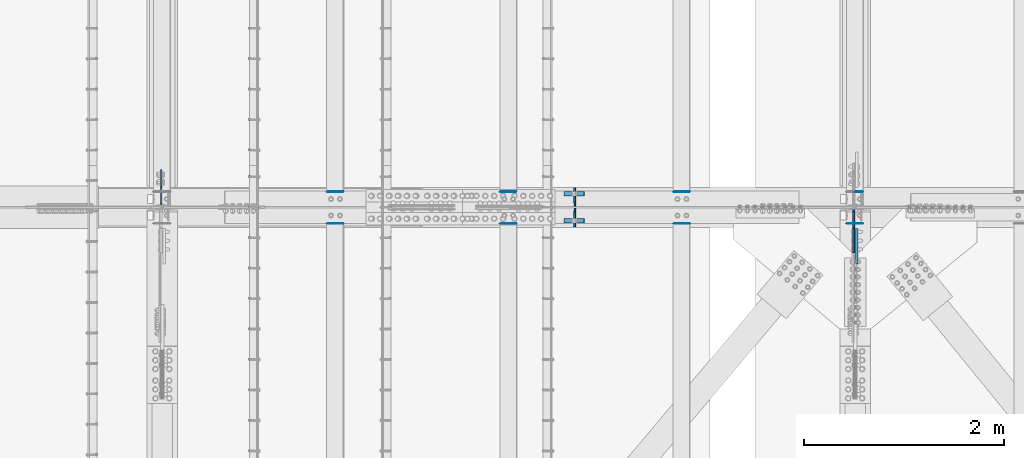
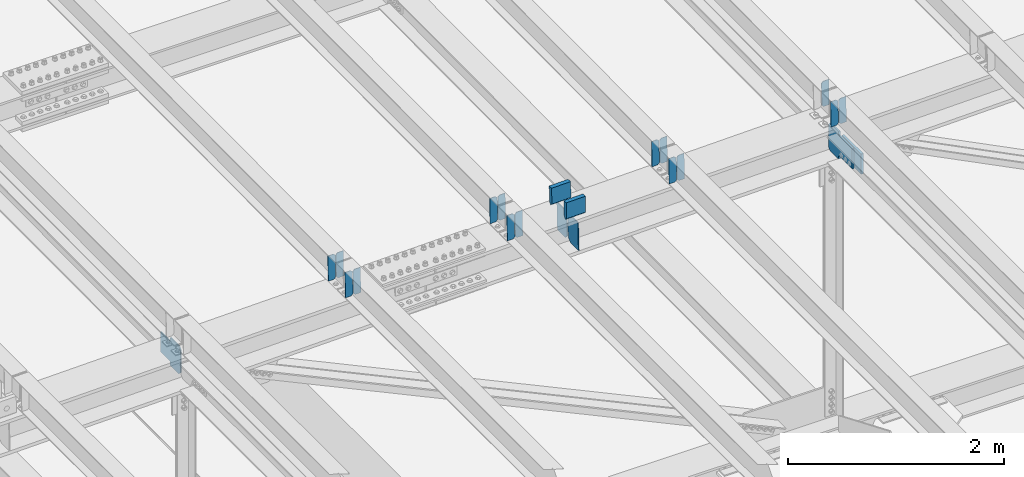
# One storey, part 3290 of 3843: 22 plates, 11 elements without a shape of their own.
"""IFC2X3 building model written with IfcOpenShell, lengths in millimetres."""

from ifc_helpers import new_model, si_unit, frame, origin_with_axes, place, context, subcontext, project, spatial, faceted_brep, material, type_object, element, aggregate, save


model = new_model("IFC2X3")

# Units and contexts
model_context = context("Model", 3, precision=1e-05, world=origin_with_axes())
body_context = subcontext(model_context, "Body", "Model", "MODEL_VIEW")
ifc_project = project(units=[si_unit("LENGTHUNIT", "METRE", prefix="MILLI"), si_unit("AREAUNIT", "SQUARE_METRE"), si_unit("VOLUMEUNIT", "CUBIC_METRE"), si_unit("MASSUNIT", "GRAM", prefix="KILO"), si_unit("TIMEUNIT", "SECOND"), si_unit("PLANEANGLEUNIT", "RADIAN"), si_unit("SOLIDANGLEUNIT", "STERADIAN"), si_unit("THERMODYNAMICTEMPERATUREUNIT", "DEGREE_CELSIUS"), si_unit("LUMINOUSINTENSITYUNIT", "LUMEN")], contexts=[model_context])

# Site, building, storey
site_placement = place(None, origin_with_axes())
site = spatial("IfcSite", under=ifc_project, at=site_placement, CompositionType="ELEMENT")
building_placement = place(site_placement, origin_with_axes())
building = spatial("IfcBuilding", under=site, at=building_placement, Name="Undefined", CompositionType="ELEMENT")
storey_placement = place(building_placement, origin_with_axes())
storey = spatial("IfcBuildingStorey", under=building, at=storey_placement, Name="Undefined", CompositionType="ELEMENT", Elevation=0.0)

# Assembly, plate
assembly_1_placement = place(storey_placement, origin_with_axes())
assembly_1 = element("IfcElementAssembly", 1, at=assembly_1_placement, inside=storey, Name="BEAM", AssemblyPlace="NOTDEFINED", PredefinedType="RIGID_FRAME")
ifc_material = material(Name="STEEL/A572-50")
plate_type_1 = type_object("IfcPlateType", PredefinedType="NOTDEFINED")
plate_1_placement = place(assembly_1_placement, frame((56013.0964783436, 34003.2151362822, 45851.1922234992), z_axis=(-0.0211520978450862, -0.00720209800074371, 0.999750328102542), x_axis=(-0.999776269350674, 0.000152374000020299, -0.0211515490073949)))
plate_1 = element("IfcPlate", 2, at=plate_1_placement, type_object=plate_type_1, material=ifc_material, Name="PLATE", context=body_context, shape_type="Brep", body=[
    faceted_brep([(0.0, -3.17499999999927, 0.0), (6.83940015733242e-10, -3.17499999996653, 288.924999998613), (6.54836185276508e-10, 3.17500000001746, 288.924999998591), (0.0, 3.17499999999927, 0.0), (60.3250007643655, -3.17500000017753, 288.924999998606), (60.3250007643219, 3.17499999979918, 288.924999998584), (79.3750000013097, -3.17500000025029, 269.875000761494), (79.375000001266, 3.17499999972642, 269.875000761487), (79.375000000713, -3.17500000026484, 19.0499992370605), (79.3750000006985, 3.17499999971187, 19.0499992370533), (60.325000763667, -3.17500000020664, -1.45519152283669e-11), (60.3250007636234, 3.17499999977736, -3.63797880709171e-11)], [[[0, 1, 2, 3]], [[1, 4, 5, 2]], [[4, 6, 7, 5]], [[6, 8, 9, 7]], [[8, 10, 11, 9]], [[10, 0, 3, 11]], [[5, 7, 9, 11, 3, 2]], [[10, 8, 6, 4, 1, 0]]]),
])
aggregate(assembly_1, [plate_1])

# Assembly, plates
assembly_2_placement = place(storey_placement, origin_with_axes())
assembly_2 = element("IfcElementAssembly", 3, at=assembly_2_placement, inside=storey, Name="BEAM", AssemblyPlace="NOTDEFINED", PredefinedType="RIGID_FRAME")
plate_2_placement = place(assembly_2_placement, frame((56013.0964782657, 33683.8902484388, 45849.8849977929), z_axis=(-0.0211520978121262, -0.00105623500043294, 0.999775711410199), x_axis=(-0.999776269351372, 2.23470000204419e-05, -0.0211520860074212)))
plate_2 = element("IfcPlate", 4, at=plate_2_placement, type_object=plate_type_1, material=ifc_material, Name="PLATE", context=body_context, shape_type="Brep", body=[
    faceted_brep([(0.0, -3.17499999999927, 0.0), (6.83940015733242e-10, -3.17499999996653, 288.924999998613), (6.54836185276508e-10, 3.17500000001746, 288.924999998591), (0.0, 3.17499999999927, 0.0), (60.3250007643655, -3.17500000017753, 288.924999998606), (60.3250007643219, 3.17499999979918, 288.924999998584), (79.3750000013097, -3.17500000025029, 269.875000761494), (79.375000001266, 3.17499999972642, 269.875000761487), (79.375000000713, -3.17500000026484, 19.0499992370605), (79.3750000006985, 3.17499999971187, 19.0499992370533), (60.325000763667, -3.17500000020664, -1.45519152283669e-11), (60.3250007636234, 3.17499999977736, -3.63797880709171e-11)], [[[0, 1, 2, 3]], [[1, 4, 5, 2]], [[4, 6, 7, 5]], [[6, 8, 9, 7]], [[8, 10, 11, 9]], [[10, 0, 3, 11]], [[5, 7, 9, 11, 3, 2]], [[10, 8, 6, 4, 1, 0]]]),
])
plate_3_placement = place(assembly_2_placement, frame((55927.390657576, 33683.892164099, 45848.0717352026), z_axis=(-0.0211520978121262, -0.00105623500043294, 0.999775711410199), x_axis=(-0.999776269351372, 2.23470000204419e-05, -0.0211520860074212)))
plate_3 = element("IfcPlate", 5, at=plate_3_placement, type_object=plate_type_1, material=ifc_material, Name="PLATE", context=body_context, shape_type="Brep", body=[
    faceted_brep([(4.36557456851006e-11, -3.17499999998836, 19.0499992370969), (6.11180439591408e-10, -3.17499999996653, 269.875000761516), (5.96628524363041e-10, 3.17500000001746, 269.875000761502), (1.45519152283669e-11, 3.17499999998836, 19.0499992370824), (19.0499992376572, -3.17500000003201, 288.924999998606), (19.0499992376281, 3.1749999999447, 288.924999998584), (79.3750000013242, -3.17500000025029, 288.924999998591), (79.3750000013097, 3.1749999997337, 288.92499999857), (79.3750000006548, -3.17500000026484, -2.18278728425503e-11), (79.3750000006403, 3.17499999969732, -2.91038304567337e-11), (19.0499992370023, -3.17500000005384, 0.0), (19.0499992369587, 3.17499999992287, -1.45519152283669e-11)], [[[0, 1, 2, 3]], [[1, 4, 5, 2]], [[4, 6, 7, 5]], [[6, 8, 9, 7]], [[8, 10, 11, 9]], [[10, 0, 3, 11]], [[5, 7, 9, 11, 3, 2]], [[10, 8, 6, 4, 1, 0]]]),
])
aggregate(assembly_2, [plate_2, plate_3])

assembly_3_placement = place(storey_placement, origin_with_axes())
assembly_3 = element("IfcElementAssembly", 6, at=assembly_3_placement, inside=storey, Name="BEAM", AssemblyPlace="NOTDEFINED", PredefinedType="RIGID_FRAME")
plate_4_placement = place(assembly_3_placement, frame((54279.5464782748, 34003.1156939734, 45813.6257052676), z_axis=(-0.0211520978615081, -0.00686633299678943, 0.999752690532631), x_axis=(-0.999776269350327, 0.000145270000029235, -0.0211515990074044)))
plate_4 = element("IfcPlate", 7, at=plate_4_placement, type_object=plate_type_1, material=ifc_material, Name="PLATE", context=body_context, shape_type="Brep", body=[
    faceted_brep([(0.0, -3.17499999999927, 0.0), (6.83940015733242e-10, -3.17499999996653, 288.924999998613), (6.54836185276508e-10, 3.17500000001746, 288.924999998591), (0.0, 3.17499999999927, 0.0), (60.3250007643655, -3.17500000017753, 288.924999998606), (60.3250007643219, 3.17499999979918, 288.924999998584), (79.3750000013097, -3.17500000025029, 269.875000761494), (79.375000001266, 3.17499999972642, 269.875000761487), (79.375000000713, -3.17500000026484, 19.0499992370605), (79.3750000006985, 3.17499999971187, 19.0499992370533), (60.325000763667, -3.17500000020664, -1.45519152283669e-11), (60.3250007636234, 3.17499999977736, -3.63797880709171e-11)], [[[0, 1, 2, 3]], [[1, 4, 5, 2]], [[4, 6, 7, 5]], [[6, 8, 9, 7]], [[8, 10, 11, 9]], [[10, 0, 3, 11]], [[5, 7, 9, 11, 3, 2]], [[10, 8, 6, 4, 1, 0]]]),
])
plate_5_placement = place(assembly_3_placement, frame((54193.8406575855, 34003.1281472298, 45811.8124844316), z_axis=(-0.0211520978615081, -0.00686633299678943, 0.999752690532631), x_axis=(-0.999776269350327, 0.000145270000029235, -0.0211515990074044)))
plate_5 = element("IfcPlate", 8, at=plate_5_placement, type_object=plate_type_1, material=ifc_material, Name="PLATE", context=body_context, shape_type="Brep", body=[
    faceted_brep([(4.36557456851006e-11, -3.17499999998836, 19.0499992370969), (6.11180439591408e-10, -3.17499999996653, 269.875000761516), (5.96628524363041e-10, 3.17500000001746, 269.875000761502), (1.45519152283669e-11, 3.17499999998836, 19.0499992370824), (19.0499992376572, -3.17500000003201, 288.924999998606), (19.0499992376281, 3.1749999999447, 288.924999998584), (79.3750000013242, -3.17500000025029, 288.924999998591), (79.3750000013097, 3.1749999997337, 288.92499999857), (79.3750000006548, -3.17500000026484, -2.18278728425503e-11), (79.3750000006403, 3.17499999969732, -2.91038304567337e-11), (19.0499992370023, -3.17500000005384, 0.0), (19.0499992369587, 3.17499999992287, -1.45519152283669e-11)], [[[0, 1, 2, 3]], [[1, 4, 5, 2]], [[4, 6, 7, 5]], [[6, 8, 9, 7]], [[8, 10, 11, 9]], [[10, 0, 3, 11]], [[5, 7, 9, 11, 3, 2]], [[10, 8, 6, 4, 1, 0]]]),
])
aggregate(assembly_3, [plate_4, plate_5])

assembly_4_placement = place(storey_placement, origin_with_axes())
assembly_4 = element("IfcElementAssembly", 9, at=assembly_4_placement, inside=storey, Name="BEAM", AssemblyPlace="NOTDEFINED", PredefinedType="RIGID_FRAME")
plate_6_placement = place(assembly_4_placement, frame((54279.5464782638, 33683.8619929527, 45812.3874260212), z_axis=(-0.0211520977917825, -0.000961630999885527, 0.999775806881136), x_axis=(-0.999776269351802, 2.0345000001943e-05, -0.0211520880074333)))
plate_6 = element("IfcPlate", 10, at=plate_6_placement, type_object=plate_type_1, material=ifc_material, Name="PLATE", context=body_context, shape_type="Brep", body=[
    faceted_brep([(0.0, -3.17499999999927, 0.0), (6.83940015733242e-10, -3.17499999996653, 288.924999998613), (6.54836185276508e-10, 3.17500000001746, 288.924999998591), (0.0, 3.17499999999927, 0.0), (60.3250007643655, -3.17500000017753, 288.924999998606), (60.3250007643219, 3.17499999979918, 288.924999998584), (79.3750000013097, -3.17500000025029, 269.875000761494), (79.375000001266, 3.17499999972642, 269.875000761487), (79.375000000713, -3.17500000026484, 19.0499992370605), (79.3750000006985, 3.17499999971187, 19.0499992370533), (60.325000763667, -3.17500000020664, -1.45519152283669e-11), (60.3250007636234, 3.17499999977736, -3.63797880709171e-11)], [[[0, 1, 2, 3]], [[1, 4, 5, 2]], [[4, 6, 7, 5]], [[6, 8, 9, 7]], [[8, 10, 11, 9]], [[10, 0, 3, 11]], [[5, 7, 9, 11, 3, 2]], [[10, 8, 6, 4, 1, 0]]]),
])
plate_7_placement = place(assembly_4_placement, frame((54193.8406575745, 33683.8637370322, 45810.5741632592), z_axis=(-0.0211520977917825, -0.000961630999885527, 0.999775806881136), x_axis=(-0.999776269351802, 2.0345000001943e-05, -0.0211520880074333)))
plate_7 = element("IfcPlate", 11, at=plate_7_placement, type_object=plate_type_1, material=ifc_material, Name="PLATE", context=body_context, shape_type="Brep", body=[
    faceted_brep([(4.36557456851006e-11, -3.17499999998836, 19.0499992370969), (6.11180439591408e-10, -3.17499999996653, 269.875000761516), (5.96628524363041e-10, 3.17500000001746, 269.875000761502), (1.45519152283669e-11, 3.17499999998836, 19.0499992370824), (19.0499992376572, -3.17500000003201, 288.924999998606), (19.0499992376281, 3.1749999999447, 288.924999998584), (79.3750000013242, -3.17500000025029, 288.924999998591), (79.3750000013097, 3.1749999997337, 288.92499999857), (79.3750000006548, -3.17500000026484, -2.18278728425503e-11), (79.3750000006403, 3.17499999969732, -2.91038304567337e-11), (19.0499992370023, -3.17500000005384, 0.0), (19.0499992369587, 3.17499999992287, -1.45519152283669e-11)], [[[0, 1, 2, 3]], [[1, 4, 5, 2]], [[4, 6, 7, 5]], [[6, 8, 9, 7]], [[8, 10, 11, 9]], [[10, 0, 3, 11]], [[5, 7, 9, 11, 3, 2]], [[10, 8, 6, 4, 1, 0]]]),
])
aggregate(assembly_4, [plate_6, plate_7])

assembly_5_placement = place(storey_placement, origin_with_axes())
assembly_5 = element("IfcElementAssembly", 12, at=assembly_5_placement, inside=storey, Name="BEAM", AssemblyPlace="NOTDEFINED", PredefinedType="RIGID_FRAME")
plate_8_placement = place(assembly_5_placement, frame((52545.9964782752, 34002.9975009205, 45776.0491563071), z_axis=(-0.0211520975599923, -0.00646726799793394, 0.999755351680328), x_axis=(-0.999776269356706, 0.000136827000078921, -0.0211516550075725)))
plate_8 = element("IfcPlate", 13, at=plate_8_placement, type_object=plate_type_1, material=ifc_material, Name="PLATE", context=body_context, shape_type="Brep", body=[
    faceted_brep([(0.0, -3.17499999999927, 0.0), (6.83940015733242e-10, -3.17499999996653, 288.924999998613), (6.54836185276508e-10, 3.17500000001746, 288.924999998591), (0.0, 3.17499999999927, 0.0), (60.3250007643655, -3.17500000017753, 288.924999998606), (60.3250007643219, 3.17499999979918, 288.924999998584), (79.3750000013097, -3.17500000025029, 269.875000761494), (79.375000001266, 3.17499999972642, 269.875000761487), (79.375000000713, -3.17500000026484, 19.0499992370605), (79.3750000006985, 3.17499999971187, 19.0499992370533), (60.325000763667, -3.17500000020664, -1.45519152283669e-11), (60.3250007636234, 3.17499999977736, -3.63797880709171e-11)], [[[0, 1, 2, 3]], [[1, 4, 5, 2]], [[4, 6, 7, 5]], [[6, 8, 9, 7]], [[8, 10, 11, 9]], [[10, 0, 3, 11]], [[5, 7, 9, 11, 3, 2]], [[10, 8, 6, 4, 1, 0]]]),
])
plate_9_placement = place(assembly_5_placement, frame((52460.2906575859, 34003.0092304079, 45774.2359306445), z_axis=(-0.0211520975599923, -0.00646726799793394, 0.999755351680328), x_axis=(-0.999776269356706, 0.000136827000078921, -0.0211516550075725)))
plate_9 = element("IfcPlate", 14, at=plate_9_placement, type_object=plate_type_1, material=ifc_material, Name="PLATE", context=body_context, shape_type="Brep", body=[
    faceted_brep([(4.36557456851006e-11, -3.17499999998836, 19.0499992370969), (6.11180439591408e-10, -3.17499999996653, 269.875000761516), (5.96628524363041e-10, 3.17500000001746, 269.875000761502), (1.45519152283669e-11, 3.17499999998836, 19.0499992370824), (19.0499992376572, -3.17500000003201, 288.924999998606), (19.0499992376281, 3.1749999999447, 288.924999998584), (79.3750000013242, -3.17500000025029, 288.924999998591), (79.3750000013097, 3.1749999997337, 288.92499999857), (79.3750000006548, -3.17500000026484, -2.18278728425503e-11), (79.3750000006403, 3.17499999969732, -2.91038304567337e-11), (19.0499992370023, -3.17500000005384, 0.0), (19.0499992369587, 3.17499999992287, -1.45519152283669e-11)], [[[0, 1, 2, 3]], [[1, 4, 5, 2]], [[4, 6, 7, 5]], [[6, 8, 9, 7]], [[8, 10, 11, 9]], [[10, 0, 3, 11]], [[5, 7, 9, 11, 3, 2]], [[10, 8, 6, 4, 1, 0]]]),
])
aggregate(assembly_5, [plate_8, plate_9])

assembly_6_placement = place(storey_placement, origin_with_axes())
assembly_6 = element("IfcElementAssembly", 15, at=assembly_6_placement, inside=storey, Name="BEAM", AssemblyPlace="NOTDEFINED", PredefinedType="RIGID_FRAME")
plate_10_placement = place(assembly_6_placement, frame((52545.996478265, 33683.8312435383, 45774.8898608673), z_axis=(-0.0211520979617634, -0.000867027000342203, 0.999775893396113), x_axis=(-0.999776269348206, 1.83440000095906e-05, -0.0211520900074109)))
plate_10 = element("IfcPlate", 16, at=plate_10_placement, type_object=plate_type_1, material=ifc_material, Name="PLATE", context=body_context, shape_type="Brep", body=[
    faceted_brep([(0.0, -3.17499999999927, 0.0), (6.83940015733242e-10, -3.17499999996653, 288.924999998613), (6.54836185276508e-10, 3.17500000001746, 288.924999998591), (0.0, 3.17499999999927, 0.0), (60.3250007643655, -3.17500000017753, 288.924999998606), (60.3250007643219, 3.17499999979918, 288.924999998584), (79.3750000013097, -3.17500000025029, 269.875000761494), (79.375000001266, 3.17499999972642, 269.875000761487), (79.375000000713, -3.17500000026484, 19.0499992370605), (79.3750000006985, 3.17499999971187, 19.0499992370533), (60.325000763667, -3.17500000020664, -1.45519152283669e-11), (60.3250007636234, 3.17499999977736, -3.63797880709171e-11)], [[[0, 1, 2, 3]], [[1, 4, 5, 2]], [[4, 6, 7, 5]], [[6, 8, 9, 7]], [[8, 10, 11, 9]], [[10, 0, 3, 11]], [[5, 7, 9, 11, 3, 2]], [[10, 8, 6, 4, 1, 0]]]),
])
plate_11_placement = place(assembly_6_placement, frame((52460.2906575756, 33683.8328160392, 45773.0765979471), z_axis=(-0.0211520979617634, -0.000867027000342203, 0.999775893396113), x_axis=(-0.999776269348206, 1.83440000095906e-05, -0.0211520900074109)))
plate_11 = element("IfcPlate", 17, at=plate_11_placement, type_object=plate_type_1, material=ifc_material, Name="PLATE", context=body_context, shape_type="Brep", body=[
    faceted_brep([(4.36557456851006e-11, -3.17499999998836, 19.0499992370969), (6.11180439591408e-10, -3.17499999996653, 269.875000761516), (5.96628524363041e-10, 3.17500000001746, 269.875000761502), (1.45519152283669e-11, 3.17499999998836, 19.0499992370824), (19.0499992376572, -3.17500000003201, 288.924999998606), (19.0499992376281, 3.1749999999447, 288.924999998584), (79.3750000013242, -3.17500000025029, 288.924999998591), (79.3750000013097, 3.1749999997337, 288.92499999857), (79.3750000006548, -3.17500000026484, -2.18278728425503e-11), (79.3750000006403, 3.17499999969732, -2.91038304567337e-11), (19.0499992370023, -3.17500000005384, 0.0), (19.0499992369587, 3.17499999992287, -1.45519152283669e-11)], [[[0, 1, 2, 3]], [[1, 4, 5, 2]], [[4, 6, 7, 5]], [[6, 8, 9, 7]], [[8, 10, 11, 9]], [[10, 0, 3, 11]], [[5, 7, 9, 11, 3, 2]], [[10, 8, 6, 4, 1, 0]]]),
])
aggregate(assembly_6, [plate_10, plate_11])

assembly_7_placement = place(storey_placement, origin_with_axes())
assembly_7 = element("IfcElementAssembly", 18, at=assembly_7_placement, inside=storey, Name="BEAM", AssemblyPlace="NOTDEFINED", PredefinedType="RIGID_FRAME")
plate_12_placement = place(assembly_7_placement, frame((50812.4464782769, 34003.1037015849, 45731.7644254659), z_axis=(-0.0211520979861161, -0.00682580700029211, 0.999752968042396), x_axis=(-0.999776269353726, 0.000143930000091341, -0.021151608007443)))
plate_12 = element("IfcPlate", 19, at=plate_12_placement, type_object=plate_type_1, material=ifc_material, Name="PLATE", context=body_context, shape_type="Brep", body=[
    faceted_brep([(0.0, -3.17499999999927, 0.0), (6.83940015733242e-10, -3.17499999996653, 288.924999998613), (6.54836185276508e-10, 3.17500000001746, 288.924999998591), (0.0, 3.17499999999927, 0.0), (60.3250007643655, -3.17500000017753, 288.924999998606), (60.3250007643219, 3.17499999979918, 288.924999998584), (79.3750000013097, -3.17500000025029, 269.875000761494), (79.375000001266, 3.17499999972642, 269.875000761487), (79.375000000713, -3.17500000026484, 19.0499992370605), (79.3750000006985, 3.17499999971187, 19.0499992370533), (60.325000763667, -3.17500000020664, -1.45519152283669e-11), (60.3250007636234, 3.17499999977736, -3.63797880709171e-11)], [[[0, 1, 2, 3]], [[1, 4, 5, 2]], [[4, 6, 7, 5]], [[6, 8, 9, 7]], [[8, 10, 11, 9]], [[10, 0, 3, 11]], [[5, 7, 9, 11, 3, 2]], [[10, 8, 6, 4, 1, 0]]]),
])
plate_13_placement = place(assembly_7_placement, frame((50726.7406575876, 34003.1160813417, 45729.9512041258), z_axis=(-0.0211520979861161, -0.00682580700029211, 0.999752968042396), x_axis=(-0.999776269353726, 0.000143930000091341, -0.021151608007443)))
plate_13 = element("IfcPlate", 20, at=plate_13_placement, type_object=plate_type_1, material=ifc_material, Name="PLATE", context=body_context, shape_type="Brep", body=[
    faceted_brep([(4.36557456851006e-11, -3.17499999998836, 19.0499992370969), (6.11180439591408e-10, -3.17499999996653, 269.875000761516), (5.96628524363041e-10, 3.17500000001746, 269.875000761502), (1.45519152283669e-11, 3.17499999998836, 19.0499992370824), (19.0499992376572, -3.17500000003201, 288.924999998606), (19.0499992376281, 3.1749999999447, 288.924999998584), (79.3750000013242, -3.17500000025029, 288.924999998591), (79.3750000013097, 3.1749999997337, 288.92499999857), (79.3750000006548, -3.17500000026484, -2.18278728425503e-11), (79.3750000006403, 3.17499999969732, -2.91038304567337e-11), (19.0499992370023, -3.17500000005384, 0.0), (19.0499992369587, 3.17499999992287, -1.45519152283669e-11)], [[[0, 1, 2, 3]], [[1, 4, 5, 2]], [[4, 6, 7, 5]], [[6, 8, 9, 7]], [[8, 10, 11, 9]], [[10, 0, 3, 11]], [[5, 7, 9, 11, 3, 2]], [[10, 8, 6, 4, 1, 0]]]),
])
aggregate(assembly_7, [plate_12, plate_13])

assembly_8_placement = place(storey_placement, origin_with_axes())
assembly_8 = element("IfcElementAssembly", 21, at=assembly_8_placement, inside=storey, Name="BEAM", AssemblyPlace="NOTDEFINED", PredefinedType="RIGID_FRAME")
plate_14_placement = place(assembly_8_placement, frame((50812.446478262, 33683.7945462322, 45737.3954422089), z_axis=(-0.0211520983200535, -0.000772423999962485, 0.999775970954405), x_axis=(-0.999776269340625, 1.63419999910023e-05, -0.0211520920071787)))
plate_14 = element("IfcPlate", 22, at=plate_14_placement, type_object=plate_type_1, material=ifc_material, Name="PLATE", context=body_context, shape_type="Brep", body=[
    faceted_brep([(0.0, -3.17499999999927, 0.0), (6.83940015733242e-10, -3.17499999996653, 288.924999998613), (6.54836185276508e-10, 3.17500000001746, 288.924999998591), (0.0, 3.17499999999927, 0.0), (60.3250007643655, -3.17500000017753, 288.924999998606), (60.3250007643219, 3.17499999979918, 288.924999998584), (79.3750000013097, -3.17500000025029, 269.875000761494), (79.375000001266, 3.17499999972642, 269.875000761487), (79.375000000713, -3.17500000026484, 19.0499992370605), (79.3750000006985, 3.17499999971187, 19.0499992370533), (60.325000763667, -3.17500000020664, -1.45519152283669e-11), (60.3250007636234, 3.17499999977736, -3.63797880709171e-11)], [[[0, 1, 2, 3]], [[1, 4, 5, 2]], [[4, 6, 7, 5]], [[6, 8, 9, 7]], [[8, 10, 11, 9]], [[10, 0, 3, 11]], [[5, 7, 9, 11, 3, 2]], [[10, 8, 6, 4, 1, 0]]]),
])
plate_15_placement = place(assembly_8_placement, frame((50726.7406575727, 33683.7959118353, 45735.5821791218), z_axis=(-0.0211520983200535, -0.000772423999962485, 0.999775970954405), x_axis=(-0.999776269340625, 1.63419999910023e-05, -0.0211520920071787)))
plate_15 = element("IfcPlate", 23, at=plate_15_placement, type_object=plate_type_1, material=ifc_material, Name="PLATE", context=body_context, shape_type="Brep", body=[
    faceted_brep([(4.36557456851006e-11, -3.17499999998836, 19.0499992370969), (6.11180439591408e-10, -3.17499999996653, 269.875000761516), (5.96628524363041e-10, 3.17500000001746, 269.875000761502), (1.45519152283669e-11, 3.17499999998836, 19.0499992370824), (19.0499992376572, -3.17500000003201, 288.924999998606), (19.0499992376281, 3.1749999999447, 288.924999998584), (79.3750000013242, -3.17500000025029, 288.924999998591), (79.3750000013097, 3.1749999997337, 288.92499999857), (79.3750000006548, -3.17500000026484, -2.18278728425503e-11), (79.3750000006403, 3.17499999969732, -2.91038304567337e-11), (19.0499992370023, -3.17500000005384, 0.0), (19.0499992369587, 3.17499999992287, -1.45519152283669e-11)], [[[0, 1, 2, 3]], [[1, 4, 5, 2]], [[4, 6, 7, 5]], [[6, 8, 9, 7]], [[8, 10, 11, 9]], [[10, 0, 3, 11]], [[5, 7, 9, 11, 3, 2]], [[10, 8, 6, 4, 1, 0]]]),
])
aggregate(assembly_8, [plate_14, plate_15])

assembly_9_placement = place(storey_placement, origin_with_axes())
assembly_9 = element("IfcElementAssembly", 24, at=assembly_9_placement, inside=storey, Name="BEAM", AssemblyPlace="NOTDEFINED", PredefinedType="RIGID_FRAME")
plate_type_2 = type_object("IfcPlateType", PredefinedType="NOTDEFINED")
plate_16_placement = place(assembly_9_placement, frame((53128.0045535556, 33650.2375, 45420.8657875967), z_axis=(-0.0216342480057937, 0.0, 0.999765952267441), x_axis=(0.0, 1.0, 0.0)))
plate_16 = element("IfcPlate", 25, at=plate_16_placement, type_object=plate_type_2, material=ifc_material, Name="PL", context=body_context, shape_type="Brep", body=[
    faceted_brep([(0.0, -4.76249999999709, 0.0), (0.0, -4.76249999785796, 317.500000005042), (0.0, 4.76250000210712, 317.50000000505), (0.0, 4.76249999999709, 0.0), (146.050001525873, -4.76249999785796, 317.500000005042), (146.050001525873, 4.76250000210712, 317.50000000505), (184.149999999994, -4.76249999810534, 279.400001530797), (184.149999999994, 4.76250000185973, 279.400001530805), (184.149999999994, -4.7624999997206, 38.0999984742448), (184.149999999994, 4.76250000022992, 38.0999984742448), (146.049999999988, -4.76250000000073, 0.0), (146.049999999988, 4.76250000000073, 0.0)], [[[0, 1, 2, 3]], [[1, 4, 5, 2]], [[4, 6, 7, 5]], [[6, 8, 9, 7]], [[8, 10, 11, 9]], [[10, 0, 3, 11]], [[5, 7, 9, 11, 3, 2]], [[10, 8, 6, 4, 1, 0]]]),
])
plate_17_placement = place(assembly_9_placement, frame((53128.0045535556, 33856.6125, 45420.8657875967), z_axis=(-0.0216342480057937, 0.0, 0.999765952267441), x_axis=(0.0, 1.0, 0.0)))
plate_17 = element("IfcPlate", 26, at=plate_17_placement, type_object=plate_type_2, material=ifc_material, Name="PL", context=body_context, shape_type="Brep", body=[
    faceted_brep([(0.0, -4.76250000000073, 38.0999999999985), (0.0, -4.76249999810534, 279.400001530797), (0.0, 4.76250000185973, 279.400001530805), (0.0, 4.76250000000073, 38.0999999999985), (38.0999984741211, -4.76249999785796, 317.500000005042), (38.0999984741211, 4.76250000210712, 317.50000000505), (184.150000000009, -4.76249999999709, 317.5), (184.150000000009, 4.76249999999709, 317.5), (184.150000000009, -4.76249999999709, 0.0), (184.150000000009, 4.76249999999709, 0.0), (38.0999984741211, -4.76249999996799, 0.0), (38.0999984741211, 4.76249999998254, 0.0)], [[[0, 1, 2, 3]], [[1, 4, 5, 2]], [[4, 6, 7, 5]], [[6, 8, 9, 7]], [[8, 10, 11, 9]], [[10, 0, 3, 11]], [[5, 7, 9, 11, 3, 2]], [[10, 8, 6, 4, 1, 0]]]),
])
plate_type_3 = type_object("IfcPlateType", PredefinedType="NOTDEFINED")
plate_18_placement = place(assembly_9_placement, frame((53014.6596096478, 33981.628125, 45977.2586777603), z_axis=(0.0217666070074993, 0.0, -0.999763079343992), x_axis=(0.999763079343992, 0.0, 0.0217666070075027)))
plate_18 = element("IfcPlate", 27, at=plate_18_placement, type_object=plate_type_3, material=ifc_material, Name="PLATE", context=body_context, shape_type="Brep", body=[
    faceted_brep([(203.200005058941, -22.2250000000058, -1.16415321826935e-10), (7.27595761418343e-12, -22.2250000000058, -7.27595761418343e-12), (7.27595761418343e-12, 22.2250000000058, -7.27595761418343e-12), (203.200005058941, 22.2250000000058, -1.16415321826935e-10), (203.838531807472, -22.2250000000058, 0.00187068080413155), (203.838531807472, 22.2250000000058, 0.00187068080413155), (203.310341304641, -22.2250000000058, 180.861817383484), (0.04046799018397, -22.2250000000058, 180.907287948779), (203.245434494536, 0.0133131837355904, 203.086833080139), (0.0454396034692763, 0.0133129994646879, 203.132287829787), (0.0404679902494536, 22.2250000000058, 180.907288225317), (203.310341303353, 22.2250000000058, 180.861817822159)], [[[0, 1, 2, 3]], [[4, 0, 3, 5]], [[1, 0, 4, 6, 7]], [[7, 6, 8, 9]], [[2, 1, 7, 9, 10]], [[5, 3, 2, 10, 11]], [[6, 4, 5, 11, 8]], [[10, 9, 8, 11]]]),
])
plate_19_placement = place(assembly_9_placement, frame((53014.6596096478, 33708.578125, 45977.2586777603), z_axis=(0.0217666070074993, 0.0, -0.999763079343992), x_axis=(0.999763079343992, 0.0, 0.0217666070075027)))
plate_19 = element("IfcPlate", 28, at=plate_19_placement, type_object=plate_type_3, material=ifc_material, Name="PLATE", context=body_context, shape_type="Brep", body=[
    faceted_brep([(203.200005058941, -22.2250000000058, -1.16415321826935e-10), (7.27595761418343e-12, -22.2250000000058, -7.27595761418343e-12), (7.27595761418343e-12, 22.2250000000058, -7.27595761418343e-12), (203.200005058941, 22.2250000000058, -1.16415321826935e-10), (203.838531807472, -22.2250000000058, 0.00187068080413155), (203.838531807472, 22.2250000000058, 0.00187068080413155), (203.310341304641, -22.2250000000058, 180.861817383484), (0.04046799018397, -22.2250000000058, 180.907287948779), (203.245434494536, 0.0133131837355904, 203.086833080139), (0.0454396034692763, 0.0133129994646879, 203.132287829787), (0.0404679902494536, 22.2250000000058, 180.907288225317), (203.310341303353, 22.2250000000058, 180.861817822159)], [[[0, 1, 2, 3]], [[4, 0, 3, 5]], [[1, 0, 4, 6, 7]], [[7, 6, 8, 9]], [[2, 1, 7, 9, 10]], [[5, 3, 2, 10, 11]], [[6, 4, 5, 11, 8]], [[10, 9, 8, 11]]]),
])

# Assembly, plate
assembly_10_placement = place(storey_placement, origin_with_axes())
assembly_10 = element("IfcElementAssembly", 29, at=assembly_10_placement, inside=storey, Name="BEAM", AssemblyPlace="NOTDEFINED", PredefinedType="RIGID_FRAME")
plate_type_4 = type_object("IfcPlateType", PredefinedType="NOTDEFINED")
plate_20_placement = place(assembly_10_placement, frame((48985.4874998702, 33856.6125, 45363.111595788), z_axis=(0.0, 0.707106781186548, 0.707106781186548), x_axis=(5.70000238222118e-08, 0.707106781186546, -0.707106781186546)))
plate_20 = element("IfcPlate", 30, at=plate_20_placement, type_object=plate_type_4, material=ifc_material, Name="PLATE", context=body_context, shape_type="Brep", body=[
    faceted_brep([(0.0, -6.3499999046162, 0.0), (-179.46387894213, -6.35000000000582, 179.46387894213), (-179.46387894213, 6.35000000000582, 179.46387894213), (7.27595761418343e-12, 6.3499999046162, 0.0), (-179.463878941897, -6.35000000000582, 224.365159547495), (-179.463878941897, 6.35000000000582, 224.365159547495), (-68.3332094431244, -6.35000000000582, 335.495829046271), (-68.3332094431244, 6.35000000000582, 335.495829046271), (-47.1139686356564, -6.34999999999854, 314.276588236178), (-47.1139686356564, 6.34999999999854, 314.276588236178), (-42.99379216751, -6.34999999999854, 311.523574335697), (-42.99379216751, 6.34999999999854, 311.523574335697), (-38.1337126494818, -6.34999999999854, 310.556844413113), (-38.1337126494818, 6.34999999999854, 310.556844413113), (-33.2736331314463, -6.34999999999854, 311.523574335697), (-33.2736331314463, 6.34999999999854, 311.523574335697), (-29.1534566633036, -6.34999999999854, 314.276588236171), (-29.1534566633036, 6.34999999999854, 314.276588236171), (87.5898730448844, -6.34999999999854, 431.019917944359), (87.5898730448844, 6.34999999999854, 431.019917944359), (249.234483223356, -6.34999999999854, 269.375307765898), (249.234483223356, 6.34999999999854, 269.375307765898), (132.491153515168, -6.34999999999854, 152.631978057711), (132.491153515168, 6.34999999999854, 152.631978057711), (129.73813961469, -6.34999999999854, 148.511801589564), (129.73813961469, 6.34999999999854, 148.511801589564), (128.77140969211, -6.34999999999854, 143.651722071525), (128.77140969211, 6.34999999999854, 143.651722071525), (129.738139614698, -6.34999999999854, 138.791642553493), (129.738139614698, 6.34999999999854, 138.791642553493), (132.491153515168, -6.34999999999854, 134.671466085354), (132.491153515168, 6.34999999999854, 134.671466085354), (156.031950102829, -6.35000000000582, 111.130669497703), (156.031950102829, 6.35000000000582, 111.130669497703), (44.9012806051323, -6.35000000000582, -1.45519152283669e-11), (44.9012806051323, 6.35000000000582, -1.45519152283669e-11)], [[[0, 1, 2, 3]], [[1, 4, 5, 2]], [[4, 6, 7, 5]], [[6, 8, 9, 7]], [[8, 10, 11, 9]], [[10, 12, 13, 11]], [[12, 14, 15, 13]], [[14, 16, 17, 15]], [[16, 18, 19, 17]], [[18, 20, 21, 19]], [[20, 22, 23, 21]], [[22, 24, 25, 23]], [[24, 26, 27, 25]], [[26, 28, 29, 27]], [[28, 30, 31, 29]], [[30, 32, 33, 31]], [[32, 34, 35, 33]], [[34, 0, 3, 35]], [[5, 7, 9, 11, 13, 15, 17, 19, 21, 23, 25, 27, 29, 31, 33, 35, 3, 2]], [[34, 32, 30, 28, 26, 24, 22, 20, 18, 16, 14, 12, 10, 8, 6, 4, 1, 0]]]),
])
aggregate(assembly_10, [plate_20])

# Plate
plate_type_5 = type_object("IfcPlateType", PredefinedType="NOTDEFINED")
plate_21_placement = place(assembly_9_placement, frame((55916.5124995597, 33834.3875, 45513.1629312906), z_axis=(0.0, -0.707106781186682, 0.707106781186413), x_axis=(0.0, -0.707106781186548, -0.707106781186548)))
plate_21 = element("IfcPlate", 31, at=plate_21_placement, type_object=plate_type_5, material=ifc_material, Name="PLATE", context=body_context, shape_type="Brep", body=[
    faceted_brep([(0.0, -9.52500000000146, 0.0), (-179.366715657274, -9.52499999999418, 179.366715657248), (-179.366715657274, 9.52499999999418, 179.366715657248), (0.0, 9.52500000000146, 0.0), (-179.366715656826, -9.52499999999418, 224.267996262832), (-179.366715656826, 9.52499999999418, 224.267996262832), (-68.2360461568533, -9.52499999999418, 335.398665762827), (-68.2360461568533, 9.52499999999418, 335.398665762827), (-46.1232264977771, -9.52499999999418, 313.285846103783), (-46.1232264977771, 9.52499999999418, 313.285846103783), (-42.003050029638, -9.52499999999418, 310.532832203317), (-42.003050029638, 9.52499999999418, 310.532832203317), (-37.1429705115806, -9.52499999999418, 309.566102280762), (-37.1429705115806, 9.52499999999418, 309.566102280762), (-32.2828909935233, -9.52499999999418, 310.53283220336), (-32.2828909935233, 9.52499999999418, 310.53283220336), (-28.1627145253442, -9.52499999999418, 313.28584610387), (-28.1627145253442, 9.52499999999418, 313.28584610387), (142.462151912587, -9.52499999999418, 483.910712541838), (142.462151912587, 9.52499999999418, 483.910712541838), (304.106762091076, -9.52499999999418, 322.266102363385), (304.106762091076, 9.52499999999418, 322.266102363385), (133.481895653153, -9.52499999999418, 151.641235925432), (133.481895653153, 9.52499999999418, 151.641235925432), (130.728881752639, -9.52499999999418, 147.521059457242), (130.728881752639, 9.52499999999418, 147.521059457242), (129.762151830029, -9.52499999999418, 142.660979939188), (129.762151830029, 9.52499999999418, 142.660979939188), (130.728881752595, -9.52499999999418, 137.80090042112), (130.728881752595, 9.52499999999418, 137.80090042112), (133.481895653069, -9.52499999999418, 133.680723952973), (133.481895653069, 9.52499999999418, 133.680723952973), (156.031950102854, -9.52499999999418, 111.130669497732), (156.031950102854, 9.52499999999418, 111.130669497732), (44.9012806055835, -9.52499999999418, 4.65661287307739e-10), (44.9012806055835, 9.52499999999418, 4.65661287307739e-10)], [[[0, 1, 2, 3]], [[1, 4, 5, 2]], [[4, 6, 7, 5]], [[6, 8, 9, 7]], [[8, 10, 11, 9]], [[10, 12, 13, 11]], [[12, 14, 15, 13]], [[14, 16, 17, 15]], [[16, 18, 19, 17]], [[18, 20, 21, 19]], [[20, 22, 23, 21]], [[22, 24, 25, 23]], [[24, 26, 27, 25]], [[26, 28, 29, 27]], [[28, 30, 31, 29]], [[30, 32, 33, 31]], [[32, 34, 35, 33]], [[34, 0, 3, 35]], [[5, 7, 9, 11, 13, 15, 17, 19, 21, 23, 25, 27, 29, 31, 33, 35, 3, 2]], [[34, 32, 30, 28, 26, 24, 22, 20, 18, 16, 14, 12, 10, 8, 6, 4, 1, 0]]]),
])

aggregate(assembly_9, [plate_16, plate_17, plate_18, plate_19, plate_21])

# Assembly, plate
assembly_11_placement = place(storey_placement, origin_with_axes())
assembly_11 = element("IfcElementAssembly", 32, at=assembly_11_placement, inside=storey, Name="BEAM", AssemblyPlace="NOTDEFINED", PredefinedType="RIGID_FRAME")
plate_type_6 = type_object("IfcPlateType", PredefinedType="NOTDEFINED")
plate_22_placement = place(assembly_11_placement, frame((55948.2624914639, 33277.1750148966, 45526.003522008), z_axis=(0.0, 1.0, 0.0), x_axis=(0.0, 0.0, 1.0)))
plate_22 = element("IfcPlate", 33, at=plate_22_placement, type_object=plate_type_6, material=ifc_material, Name="PLATE", context=body_context, shape_type="Brep", body=[
    faceted_brep([(0.0, -12.6999999999971, 0.0), (0.0, -12.7000000000007, 355.600000000006), (0.0, 12.7000000000007, 355.600000000006), (0.0, 12.6999999999971, 0.0), (228.599998464349, -12.7000000013795, 355.599999691767), (228.599998464349, 12.6999999986292, 355.599999691869), (228.599999999991, -12.7000007629103, -5.82076609134674e-10), (228.59998398881, 12.6999999999971, -9.82254277914762e-10)], [[[0, 1, 2, 3]], [[1, 4, 5, 2]], [[4, 6, 7, 5]], [[6, 0, 3, 7]], [[5, 7, 3, 2]], [[6, 4, 1, 0]]]),
])
aggregate(assembly_11, [plate_22])

save(model, "model.ifc")
